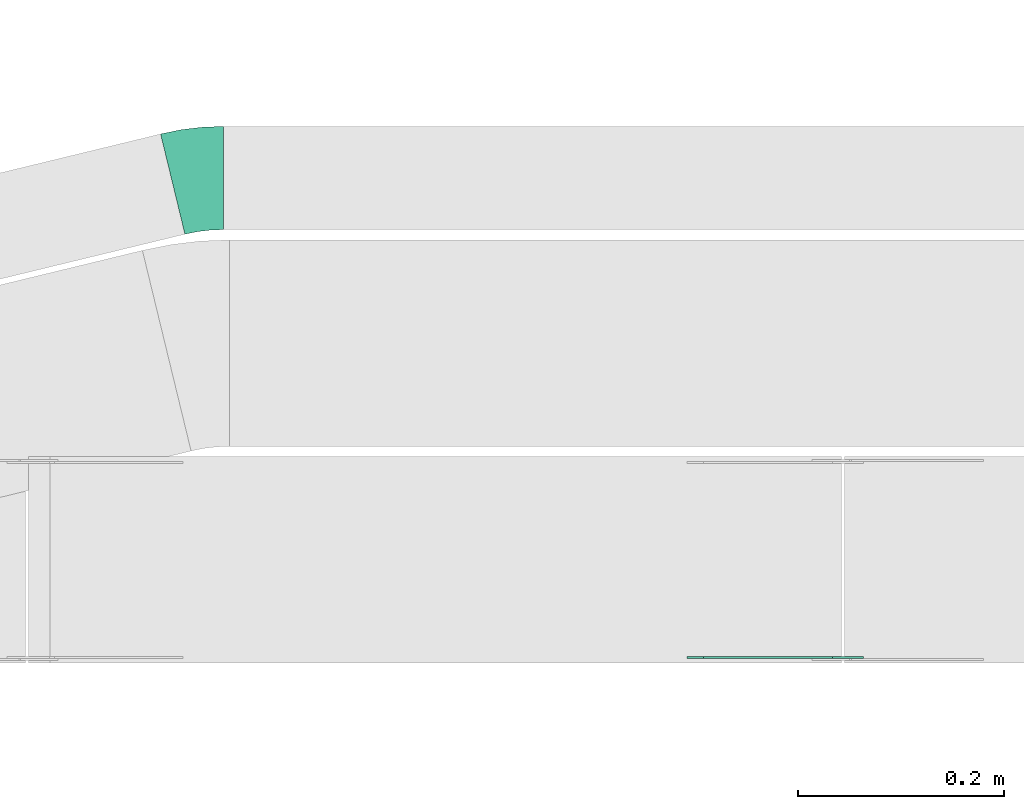
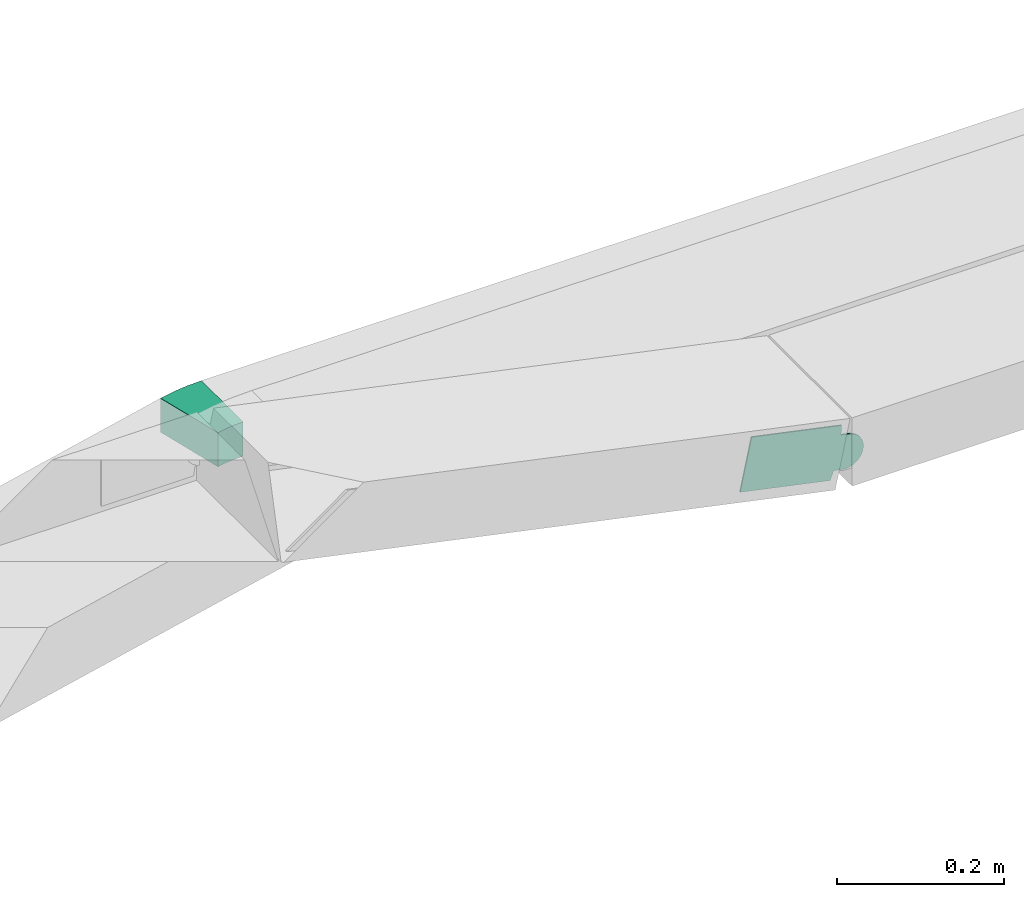
# One storey, part 18 of 25: 2 flow fittings.
"""IFC2X3 building model written with IfcOpenShell, lengths in millimetres."""

from ifc_helpers import new_model, entity, si_unit, converted_unit, derived_unit, direction, frame, frame_2d, origin, place, context, subcontext, project, spatial, polyline, circle_curve, parameter, trimmed, segment, composite_curve, outline, extrude, source, transform, mapped, material, type_object, type_shapes, element, save


model = new_model("IFC2X3")

# Units and contexts
model_context = context("Model", 3, precision=0.01, world=origin(), true_north=direction((6.12303176911189e-17, 1.0)))
body_context = subcontext(model_context, "Body", "Model", "MODEL_VIEW")
ifc_project = project(units=[si_unit("LENGTHUNIT", "METRE", prefix="MILLI"), si_unit("AREAUNIT", "SQUARE_METRE"), si_unit("VOLUMEUNIT", "CUBIC_METRE"), converted_unit("PLANEANGLEUNIT", "DEGREE", entity("IfcRatioMeasure", 0.0174532925199433), si_unit("PLANEANGLEUNIT", "RADIAN"), dimensions=[0, 0, 0, 0, 0, 0, 0]), si_unit("MASSUNIT", "GRAM", prefix="KILO"), derived_unit("MASSDENSITYUNIT", [(si_unit("MASSUNIT", "GRAM", prefix="KILO"), 1), (si_unit("LENGTHUNIT", "METRE"), -3)]), derived_unit("MOMENTOFINERTIAUNIT", [(si_unit("LENGTHUNIT", "METRE"), 4)]), si_unit("TIMEUNIT", "SECOND"), si_unit("FREQUENCYUNIT", "HERTZ"), si_unit("THERMODYNAMICTEMPERATUREUNIT", "DEGREE_CELSIUS"), derived_unit("THERMALTRANSMITTANCEUNIT", [(si_unit("MASSUNIT", "GRAM", prefix="KILO"), 1), (si_unit("THERMODYNAMICTEMPERATUREUNIT", "KELVIN"), -1), (si_unit("TIMEUNIT", "SECOND"), -3)]), derived_unit("VOLUMETRICFLOWRATEUNIT", [(si_unit("LENGTHUNIT", "METRE"), 3), (si_unit("TIMEUNIT", "SECOND"), -1)]), derived_unit("MASSFLOWRATEUNIT", [(si_unit("MASSUNIT", "GRAM", prefix="KILO"), 1), (si_unit("TIMEUNIT", "SECOND"), -1)]), derived_unit("ROTATIONALFREQUENCYUNIT", [(si_unit("TIMEUNIT", "SECOND"), -1)]), si_unit("ELECTRICCURRENTUNIT", "AMPERE"), si_unit("ELECTRICVOLTAGEUNIT", "VOLT"), si_unit("POWERUNIT", "WATT"), si_unit("FORCEUNIT", "NEWTON", prefix="KILO"), si_unit("ILLUMINANCEUNIT", "LUX"), si_unit("LUMINOUSFLUXUNIT", "LUMEN"), si_unit("LUMINOUSINTENSITYUNIT", "CANDELA"), derived_unit("USERDEFINED", [(si_unit("MASSUNIT", "GRAM", prefix="KILO"), -1), (si_unit("LENGTHUNIT", "METRE"), -2), (si_unit("TIMEUNIT", "SECOND"), 3), (si_unit("LUMINOUSFLUXUNIT", "LUMEN"), 1)]), derived_unit("LINEARVELOCITYUNIT", [(si_unit("LENGTHUNIT", "METRE"), 1), (si_unit("TIMEUNIT", "SECOND"), -1)]), si_unit("PRESSUREUNIT", "PASCAL"), derived_unit("USERDEFINED", [(si_unit("LENGTHUNIT", "METRE"), -2), (si_unit("MASSUNIT", "GRAM", prefix="KILO"), 1), (si_unit("TIMEUNIT", "SECOND"), -2)]), derived_unit("LINEARFORCEUNIT", [(si_unit("MASSUNIT", "GRAM", prefix="KILO"), 1), (si_unit("LENGTHUNIT", "METRE"), 1), (si_unit("TIMEUNIT", "SECOND"), -2), (si_unit("LENGTHUNIT", "METRE"), -1)]), derived_unit("PLANARFORCEUNIT", [(si_unit("MASSUNIT", "GRAM", prefix="KILO"), 1), (si_unit("LENGTHUNIT", "METRE"), 1), (si_unit("TIMEUNIT", "SECOND"), -2), (si_unit("LENGTHUNIT", "METRE"), -2)])], contexts=[model_context])

# Site, building, storey
site_placement = place(None, frame((0.0, -0.00077364408347762, 0.0)))
site = spatial("IfcSite", under=ifc_project, at=site_placement, CompositionType="ELEMENT")
building_placement = place(site_placement, origin())
building = spatial("IfcBuilding", under=site, at=building_placement, CompositionType="ELEMENT")
storey_placement = place(building_placement, frame((0.0, 0.0, 24000.0)))
storey = spatial("IfcBuildingStorey", under=building, at=storey_placement, CompositionType="ELEMENT", Elevation=24000.0)

# Flow fittings
ifc_material_1 = material(Name="G")
cable_carrier_fitting_type_1 = type_object("IfcCableCarrierFittingType", PredefinedType="NOTDEFINED", material=ifc_material_1)
shared_shape_1 = source(origin(), body_context, "Body", "SweptSolid", [
    extrude(outline(composite_curve([segment(trimmed(circle_curve(frame_2d((-41.4651162790697, 0.0), x_axis=(1.0, 0.0)), 25.0), [parameter(90.0000000000007)], [parameter(270.0)], True, "PARAMETER"), True, "CONTINUOUS"), segment(polyline([(-41.4651162790697, -25.0), (-29.9651162790697, -25.0)]), True, "CONTINUOUS"), segment(polyline([(-29.9651162790697, -25.0), (-28.1046511627907, -38.5)]), True, "CONTINUOUS"), segment(polyline([(-28.1046511627907, -38.5), (99.5348837209303, -38.5)]), True, "CONTINUOUS"), segment(polyline([(99.5348837209303, -38.5), (99.5348837209303, 38.5)]), True, "CONTINUOUS"), segment(polyline([(99.5348837209303, 38.5), (-28.1046511627907, 38.5)]), True, "CONTINUOUS"), segment(polyline([(-28.1046511627907, 38.5), (-29.9651162790697, 25.0)]), True, "CONTINUOUS"), segment(polyline([(-29.9651162790697, 25.0), (-41.46511627907, 25.0)]), True, "CONTINUOUS")], self_intersect=False)), frame((41.4651162790697, 0.0, 0.0)), (0.0, 0.0, 1.0), 2.0),
])
type_shapes(cable_carrier_fitting_type_1, [shared_shape_1])
flow_fitting_1_placement = place(storey_placement, frame((52328.9701607067, 8741.52923131568, 2855.0), z_axis=(0.0, -1.0, 0.0), x_axis=(-0.978349703118926, 0.0, 0.206958591044463)))
element("IfcFlowFitting", 1, at=flow_fitting_1_placement, inside=storey, type_object=cable_carrier_fitting_type_1, material=ifc_material_1, context=body_context, shape_type="MappedRepresentation", body=[
    mapped(shared_shape_1, transform((0.0, 0.0, 0.0), scale=1.0)),
])
ifc_material_2 = material()
cable_carrier_fitting_type_2 = type_object("IfcCableCarrierFittingType", Name="470_DKC_S5_Variable Angle Elbow 0-45:-", PredefinedType="NOTDEFINED", material=ifc_material_2)
shared_shape_2 = source(origin(), body_context, "Body", "SweptSolid", [
    extrude(outline(composite_curve([segment(polyline([(-24.5860461687031, -52.8820026820801), (-23.5860461687018, -52.8820026820801)]), True, "CONTINUOUS"), segment(trimmed(circle_curve(frame_2d((-23.5860461687023, 197.11799731792), x_axis=(0.0, -1.0)), 250.0), [parameter(0.0)], [parameter(13.6465105741699)], True, "PARAMETER"), True, "CONTINUOUS"), segment(polyline([(35.3967131275707, -45.8244528751205), (36.3684829283427, -45.5885218379354)]), True, "CONTINUOUS"), segment(polyline([(36.3684829283427, -45.5885218379355), (12.7753792098338, 51.5884582392807)]), True, "CONTINUOUS"), segment(polyline([(12.7753792098338, 51.5884582392807), (11.8036094090615, 51.3525272020956)]), True, "CONTINUOUS"), segment(trimmed(circle_curve(frame_2d((-23.5860461687023, 197.11799731792), x_axis=(0.0, -1.0)), 150.0), [parameter(0.0)], [parameter(13.6465105741699)], True, "PARAMETER"), False, "CONTINUOUS"), segment(polyline([(-23.5860461687018, 47.1179973179198), (-24.5860461687031, 47.1179973179198)]), True, "CONTINUOUS"), segment(polyline([(-24.5860461687031, 47.1179973179198), (-24.5860461687031, -52.8820026820801)]), True, "CONTINUOUS")], self_intersect=False)), frame((-0.344844454797808, 2.88200268207201, -25.0)), (0.0, 0.0, 1.0), 50.0000000000001),
])
type_shapes(cable_carrier_fitting_type_2, [shared_shape_2])
flow_fitting_2_placement = place(storey_placement, frame((51708.9701607067, 9204.9892313258, 2830.0), z_axis=(0.0, 0.0, 1.0), x_axis=(-1.0, 0.0, 0.0)))
element("IfcFlowFitting", 2, at=flow_fitting_2_placement, inside=storey, type_object=cable_carrier_fitting_type_2, material=ifc_material_2, Name="470_DKC_S5_Variable Angle Elbow 0-45:-", ObjectType="470_DKC_S5_Variable Angle Elbow 0-45:-", context=body_context, shape_type="MappedRepresentation", body=[
    mapped(shared_shape_2, transform((0.0, 0.0, 0.0), scale=1.0)),
])

save(model, "model.ifc")
